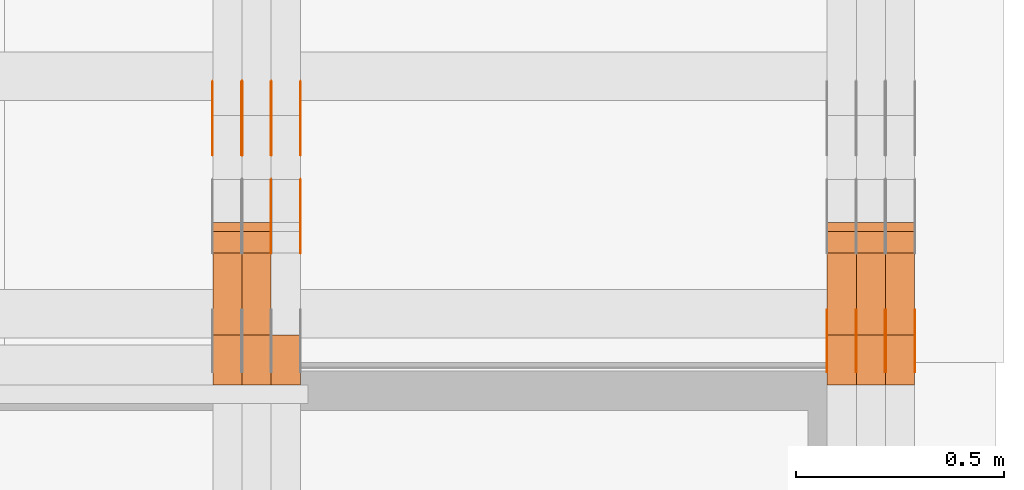
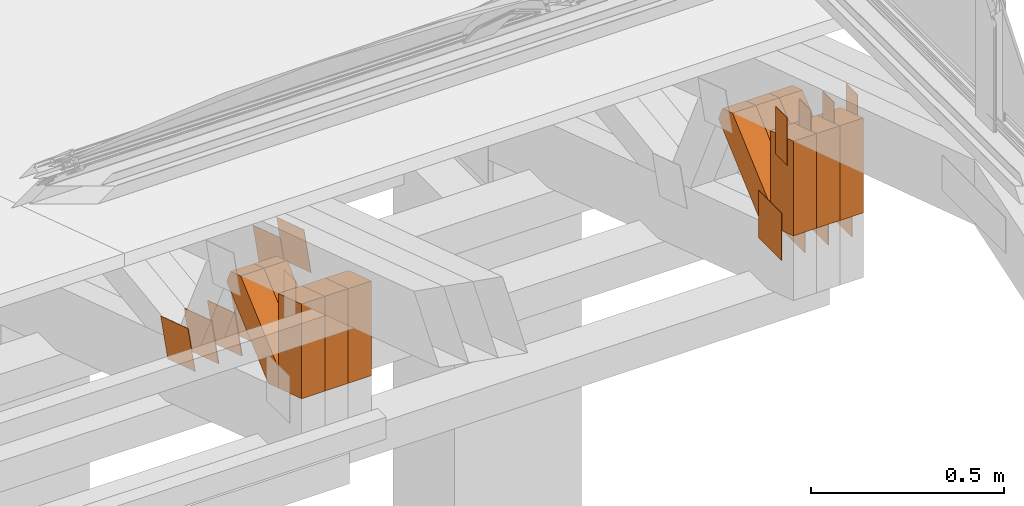
# One storey, part 325 of 385: 31 proxies.
"""IFC2X3 building model written with IfcOpenShell, lengths in millimetres."""

from ifc_helpers import new_model, entity, si_unit, converted_unit, derived_unit, direction, frame, origin, origin_2d_with_axis, place, context, subcontext, project, spatial, polyline, rectangle, outline, extrude, source, transform, mapped, material, type_object, type_shapes, element, save


model = new_model("IFC2X3")

# Units and contexts
model_context = context("Model", 3, precision=0.01, world=origin(), true_north=direction((6.12303176911189e-17, 1.0)))
body_context = subcontext(model_context, "Body", "Model", "MODEL_VIEW")
ifc_project = project(units=[si_unit("LENGTHUNIT", "METRE", prefix="MILLI"), si_unit("AREAUNIT", "SQUARE_METRE"), si_unit("VOLUMEUNIT", "CUBIC_METRE"), converted_unit("PLANEANGLEUNIT", "DEGREE", entity("IfcRatioMeasure", 0.0174532925199433), si_unit("PLANEANGLEUNIT", "RADIAN"), dimensions=[0, 0, 0, 0, 0, 0, 0]), si_unit("MASSUNIT", "GRAM", prefix="KILO"), derived_unit("MASSDENSITYUNIT", [(si_unit("MASSUNIT", "GRAM", prefix="KILO"), 1), (si_unit("LENGTHUNIT", "METRE"), -3)]), si_unit("TIMEUNIT", "SECOND"), si_unit("FREQUENCYUNIT", "HERTZ"), si_unit("THERMODYNAMICTEMPERATUREUNIT", "DEGREE_CELSIUS"), derived_unit("THERMALTRANSMITTANCEUNIT", [(si_unit("MASSUNIT", "GRAM", prefix="KILO"), 1), (si_unit("THERMODYNAMICTEMPERATUREUNIT", "KELVIN"), -1), (si_unit("TIMEUNIT", "SECOND"), -3)]), derived_unit("VOLUMETRICFLOWRATEUNIT", [(si_unit("LENGTHUNIT", "METRE"), 3), (si_unit("TIMEUNIT", "SECOND"), -1)]), si_unit("ELECTRICCURRENTUNIT", "AMPERE"), si_unit("ELECTRICVOLTAGEUNIT", "VOLT"), si_unit("POWERUNIT", "WATT"), si_unit("FORCEUNIT", "NEWTON", prefix="KILO"), si_unit("ILLUMINANCEUNIT", "LUX"), si_unit("LUMINOUSFLUXUNIT", "LUMEN"), si_unit("LUMINOUSINTENSITYUNIT", "CANDELA"), derived_unit("USERDEFINED", [(si_unit("MASSUNIT", "GRAM", prefix="KILO"), -1), (si_unit("LENGTHUNIT", "METRE"), -2), (si_unit("TIMEUNIT", "SECOND"), 3), (si_unit("LUMINOUSFLUXUNIT", "LUMEN"), 1)]), derived_unit("LINEARVELOCITYUNIT", [(si_unit("LENGTHUNIT", "METRE"), 1), (si_unit("TIMEUNIT", "SECOND"), -1)]), si_unit("PRESSUREUNIT", "PASCAL"), derived_unit("USERDEFINED", [(si_unit("LENGTHUNIT", "METRE"), -2), (si_unit("MASSUNIT", "GRAM", prefix="KILO"), 1), (si_unit("TIMEUNIT", "SECOND"), -2)])], contexts=[model_context])

# Site, building, storey
site_placement = place(None, origin())
site = spatial("IfcSite", under=ifc_project, at=site_placement, CompositionType="ELEMENT")
building_placement = place(site_placement, origin())
building = spatial("IfcBuilding", under=site, at=building_placement, CompositionType="ELEMENT")
storey_placement = place(building_placement, origin())
storey = spatial("IfcBuildingStorey", under=building, at=storey_placement, Name="Default", CompositionType="ELEMENT", Elevation=0.0)

# Proxies
ifc_material_1 = material(Name="IfcSurfaceStyle #618562")
building_element_proxy_type_1 = type_object("IfcBuildingElementProxyType", PredefinedType="NOTDEFINED", material=ifc_material_1)
shared_shape_1 = source(origin(), body_context, "Body", "SweptSolid", [
    extrude(rectangle(XDim=150.0, YDim=120.0, at=origin_2d_with_axis()), frame((75.0, 60.0, 0.0), z_axis=(0.0, 0.0, 1.0), x_axis=(-1.0, 0.0, 0.0)), (0.0, 0.0, 1.0), 1.3),
])
type_shapes(building_element_proxy_type_1, [shared_shape_1])
proxy_1_placement = place(building_placement, frame((49861.3, 15840.0, 3652.70166015625), z_axis=(-1.0, 0.0, 0.0), x_axis=(0.0, 0.0, -1.0)))
element("IfcBuildingElementProxy", 1, at=proxy_1_placement, inside=storey, type_object=building_element_proxy_type_1, material=ifc_material_1, context=body_context, shape_type="MappedRepresentation", body=[
    mapped(shared_shape_1, transform((0.0, 0.0, 0.0), scale=1.0)),
])
ifc_material_2 = material(Name="IfcSurfaceStyle #618505")
building_element_proxy_type_2 = type_object("IfcBuildingElementProxyType", PredefinedType="NOTDEFINED", material=ifc_material_2)
shared_shape_2 = source(origin(), body_context, "Body", "SweptSolid", [
    extrude(rectangle(XDim=150.0, YDim=120.0, at=origin_2d_with_axis()), frame((75.0, 60.0, 0.0), z_axis=(0.0, 0.0, 1.0), x_axis=(-1.0, 0.0, 0.0)), (0.0, 0.0, 1.0), 1.3),
])
type_shapes(building_element_proxy_type_2, [shared_shape_2])
proxy_2_placement = place(building_placement, frame((49790.0, 15840.0, 3652.70166015625), z_axis=(-1.0, 0.0, 0.0), x_axis=(0.0, 0.0, -1.0)))
element("IfcBuildingElementProxy", 2, at=proxy_2_placement, inside=storey, type_object=building_element_proxy_type_2, material=ifc_material_2, context=body_context, shape_type="MappedRepresentation", body=[
    mapped(shared_shape_2, transform((0.0, 0.0, 0.0), scale=1.0)),
])
ifc_material_3 = material(Name="IfcSurfaceStyle #618448")
building_element_proxy_type_3 = type_object("IfcBuildingElementProxyType", PredefinedType="NOTDEFINED", material=ifc_material_3)
shared_shape_3 = source(origin(), body_context, "Body", "SweptSolid", [
    extrude(rectangle(XDim=150.0, YDim=120.0, at=origin_2d_with_axis()), frame((75.0, 60.0, 0.0), z_axis=(0.0, 0.0, 1.0), x_axis=(-1.0, 0.0, 0.0)), (0.0, 0.0, 1.0), 1.3),
])
type_shapes(building_element_proxy_type_3, [shared_shape_3])
proxy_3_placement = place(building_placement, frame((49791.3, 15840.0, 3652.70166015625), z_axis=(-1.0, 0.0, 0.0), x_axis=(0.0, 0.0, -1.0)))
element("IfcBuildingElementProxy", 3, at=proxy_3_placement, inside=storey, type_object=building_element_proxy_type_3, material=ifc_material_3, context=body_context, shape_type="MappedRepresentation", body=[
    mapped(shared_shape_3, transform((0.0, 0.0, 0.0), scale=1.0)),
])
ifc_material_4 = material(Name="IfcSurfaceStyle #618391")
building_element_proxy_type_4 = type_object("IfcBuildingElementProxyType", PredefinedType="NOTDEFINED", material=ifc_material_4)
shared_shape_4 = source(origin(), body_context, "Body", "SweptSolid", [
    extrude(rectangle(XDim=150.0, YDim=120.0, at=origin_2d_with_axis()), frame((75.0, 60.0, 0.0), z_axis=(0.0, 0.0, 1.0), x_axis=(-1.0, 0.0, 0.0)), (0.0, 0.0, 1.0), 1.29999999999999),
])
type_shapes(building_element_proxy_type_4, [shared_shape_4])
proxy_4_placement = place(building_placement, frame((49720.0, 15840.0, 3652.70166015625), z_axis=(-1.0, 0.0, 0.0), x_axis=(0.0, 0.0, -1.0)))
element("IfcBuildingElementProxy", 4, at=proxy_4_placement, inside=storey, type_object=building_element_proxy_type_4, material=ifc_material_4, context=body_context, shape_type="MappedRepresentation", body=[
    mapped(shared_shape_4, transform((0.0, 0.0, 0.0), scale=1.0)),
])
ifc_material_5 = material(Name="IfcSurfaceStyle #618334")
building_element_proxy_type_5 = type_object("IfcBuildingElementProxyType", PredefinedType="NOTDEFINED", material=ifc_material_5)
shared_shape_5 = source(origin(), body_context, "Body", "SweptSolid", [
    extrude(rectangle(XDim=150.0, YDim=120.0, at=origin_2d_with_axis()), frame((75.0, 60.0, 0.0), z_axis=(0.0, 0.0, 1.0), x_axis=(-1.0, 0.0, 0.0)), (0.0, 0.0, 1.0), 1.29999999999999),
])
type_shapes(building_element_proxy_type_5, [shared_shape_5])
proxy_5_placement = place(building_placement, frame((49721.3, 15840.0, 3652.70166015625), z_axis=(-1.0, 0.0, 0.0), x_axis=(0.0, 0.0, -1.0)))
element("IfcBuildingElementProxy", 5, at=proxy_5_placement, inside=storey, type_object=building_element_proxy_type_5, material=ifc_material_5, context=body_context, shape_type="MappedRepresentation", body=[
    mapped(shared_shape_5, transform((0.0, 0.0, 0.0), scale=1.0)),
])
ifc_material_6 = material(Name="IfcSurfaceStyle #618277")
building_element_proxy_type_6 = type_object("IfcBuildingElementProxyType", PredefinedType="NOTDEFINED", material=ifc_material_6)
shared_shape_6 = source(origin(), body_context, "Body", "SweptSolid", [
    extrude(rectangle(XDim=150.0, YDim=120.0, at=origin_2d_with_axis()), frame((75.0, 60.0, 0.0), z_axis=(0.0, 0.0, 1.0), x_axis=(-1.0, 0.0, 0.0)), (0.0, 0.0, 1.0), 1.29999999999999),
])
type_shapes(building_element_proxy_type_6, [shared_shape_6])
proxy_6_placement = place(building_placement, frame((49650.0, 15840.0, 3652.70166015625), z_axis=(-1.0, 0.0, 0.0), x_axis=(0.0, 0.0, -1.0)))
element("IfcBuildingElementProxy", 6, at=proxy_6_placement, inside=storey, type_object=building_element_proxy_type_6, material=ifc_material_6, context=body_context, shape_type="MappedRepresentation", body=[
    mapped(shared_shape_6, transform((0.0, 0.0, 0.0), scale=1.0)),
])
ifc_material_7 = material(Name="IfcSurfaceStyle #613090")
building_element_proxy_type_7 = type_object("IfcBuildingElementProxyType", PredefinedType="NOTDEFINED", material=ifc_material_7)
shared_shape_7 = source(origin(), body_context, "Body", "SweptSolid", [
    extrude(rectangle(XDim=150.0, YDim=60.0, at=origin_2d_with_axis()), frame((75.0000705696311, 30.0, 0.0), z_axis=(0.0, 0.0, 1.0), x_axis=(-1.0, 0.0, 0.0)), (0.0, 0.0, 1.0), 1.3),
])
type_shapes(building_element_proxy_type_7, [shared_shape_7])
proxy_7_placement = place(building_placement, frame((49861.3, 15750.0, 3972.59919166338), z_axis=(-1.0, 0.0, 0.0), x_axis=(0.0, 0.0, -1.0)))
element("IfcBuildingElementProxy", 7, at=proxy_7_placement, inside=storey, type_object=building_element_proxy_type_7, material=ifc_material_7, context=body_context, shape_type="MappedRepresentation", body=[
    mapped(shared_shape_7, transform((0.0, 0.0, 0.0), scale=1.0)),
])
ifc_material_8 = material(Name="IfcSurfaceStyle #613033")
building_element_proxy_type_8 = type_object("IfcBuildingElementProxyType", PredefinedType="NOTDEFINED", material=ifc_material_8)
shared_shape_8 = source(origin(), body_context, "Body", "SweptSolid", [
    extrude(rectangle(XDim=150.0, YDim=60.0, at=origin_2d_with_axis()), frame((75.0000705696311, 30.0, 0.0), z_axis=(0.0, 0.0, 1.0), x_axis=(-1.0, 0.0, 0.0)), (0.0, 0.0, 1.0), 1.3),
])
type_shapes(building_element_proxy_type_8, [shared_shape_8])
proxy_8_placement = place(building_placement, frame((49790.0, 15750.0, 3972.59919166338), z_axis=(-1.0, 0.0, 0.0), x_axis=(0.0, 0.0, -1.0)))
element("IfcBuildingElementProxy", 8, at=proxy_8_placement, inside=storey, type_object=building_element_proxy_type_8, material=ifc_material_8, context=body_context, shape_type="MappedRepresentation", body=[
    mapped(shared_shape_8, transform((0.0, 0.0, 0.0), scale=1.0)),
])
ifc_material_9 = material(Name="IfcSurfaceStyle #612976")
building_element_proxy_type_9 = type_object("IfcBuildingElementProxyType", PredefinedType="NOTDEFINED", material=ifc_material_9)
shared_shape_9 = source(origin(), body_context, "Body", "SweptSolid", [
    extrude(rectangle(XDim=150.0, YDim=60.0, at=origin_2d_with_axis()), frame((75.0000705696311, 30.0, 0.0), z_axis=(0.0, 0.0, 1.0), x_axis=(-1.0, 0.0, 0.0)), (0.0, 0.0, 1.0), 1.3),
])
type_shapes(building_element_proxy_type_9, [shared_shape_9])
proxy_9_placement = place(building_placement, frame((49791.3, 15750.0, 3972.59919166338), z_axis=(-1.0, 0.0, 0.0), x_axis=(0.0, 0.0, -1.0)))
element("IfcBuildingElementProxy", 9, at=proxy_9_placement, inside=storey, type_object=building_element_proxy_type_9, material=ifc_material_9, context=body_context, shape_type="MappedRepresentation", body=[
    mapped(shared_shape_9, transform((0.0, 0.0, 0.0), scale=1.0)),
])
ifc_material_10 = material(Name="IfcSurfaceStyle #612919")
building_element_proxy_type_10 = type_object("IfcBuildingElementProxyType", PredefinedType="NOTDEFINED", material=ifc_material_10)
shared_shape_10 = source(origin(), body_context, "Body", "SweptSolid", [
    extrude(rectangle(XDim=150.0, YDim=60.0, at=origin_2d_with_axis()), frame((75.0000705696311, 30.0, 0.0), z_axis=(0.0, 0.0, 1.0), x_axis=(-1.0, 0.0, 0.0)), (0.0, 0.0, 1.0), 1.29999999999999),
])
type_shapes(building_element_proxy_type_10, [shared_shape_10])
proxy_10_placement = place(building_placement, frame((49720.0, 15750.0, 3972.59919166338), z_axis=(-1.0, 0.0, 0.0), x_axis=(0.0, 0.0, -1.0)))
element("IfcBuildingElementProxy", 10, at=proxy_10_placement, inside=storey, type_object=building_element_proxy_type_10, material=ifc_material_10, context=body_context, shape_type="MappedRepresentation", body=[
    mapped(shared_shape_10, transform((0.0, 0.0, 0.0), scale=1.0)),
])
ifc_material_11 = material(Name="IfcSurfaceStyle #612862")
building_element_proxy_type_11 = type_object("IfcBuildingElementProxyType", PredefinedType="NOTDEFINED", material=ifc_material_11)
shared_shape_11 = source(origin(), body_context, "Body", "SweptSolid", [
    extrude(rectangle(XDim=150.0, YDim=60.0, at=origin_2d_with_axis()), frame((75.0000705696311, 30.0, 0.0), z_axis=(0.0, 0.0, 1.0), x_axis=(-1.0, 0.0, 0.0)), (0.0, 0.0, 1.0), 1.29999999999999),
])
type_shapes(building_element_proxy_type_11, [shared_shape_11])
proxy_11_placement = place(building_placement, frame((49721.3, 15750.0, 3972.59919166338), z_axis=(-1.0, 0.0, 0.0), x_axis=(0.0, 0.0, -1.0)))
element("IfcBuildingElementProxy", 11, at=proxy_11_placement, inside=storey, type_object=building_element_proxy_type_11, material=ifc_material_11, context=body_context, shape_type="MappedRepresentation", body=[
    mapped(shared_shape_11, transform((0.0, 0.0, 0.0), scale=1.0)),
])
ifc_material_12 = material(Name="IfcSurfaceStyle #612805")
building_element_proxy_type_12 = type_object("IfcBuildingElementProxyType", PredefinedType="NOTDEFINED", material=ifc_material_12)
shared_shape_12 = source(origin(), body_context, "Body", "SweptSolid", [
    extrude(rectangle(XDim=150.0, YDim=60.0, at=origin_2d_with_axis()), frame((75.0000705696311, 30.0, 0.0), z_axis=(0.0, 0.0, 1.0), x_axis=(-1.0, 0.0, 0.0)), (0.0, 0.0, 1.0), 1.29999999999999),
])
type_shapes(building_element_proxy_type_12, [shared_shape_12])
proxy_12_placement = place(building_placement, frame((49650.0, 15750.0, 3972.59919166338), z_axis=(-1.0, 0.0, 0.0), x_axis=(0.0, 0.0, -1.0)))
element("IfcBuildingElementProxy", 12, at=proxy_12_placement, inside=storey, type_object=building_element_proxy_type_12, material=ifc_material_12, context=body_context, shape_type="MappedRepresentation", body=[
    mapped(shared_shape_12, transform((0.0, 0.0, 0.0), scale=1.0)),
])
ifc_material_13 = material(Name="IfcSurfaceStyle #603721")
building_element_proxy_type_13 = type_object("IfcBuildingElementProxyType", Name="T2-W50 603719", PredefinedType="NOTDEFINED", material=ifc_material_13)
shared_shape_13 = source(origin(), body_context, "Body", "SweptSolid", [
    extrude(outline(polyline([(-128.56619634284, -47.4999385885712), (133.151257249084, -47.4999385885712), (161.172800006526, -0.000129729183733609), (147.291467726413, 47.500068317755), (-142.513973767368, 47.500068317755), (-170.535354871815, -0.000129729183754689), (-128.56619634284, -47.4999385885712)])), frame((161.17310141218, 47.5001898716564, 0.0), z_axis=(0.0, 0.0, 1.0), x_axis=(-1.0, 0.0, 0.0)), (0.0, 0.0, 1.0), 70.0),
])
type_shapes(building_element_proxy_type_13, [shared_shape_13])
proxy_13_placement = place(building_placement, frame((49860.0, 16060.0297689714, 3761.73994820667), z_axis=(-1.0, 0.0, 0.0), x_axis=(0.0, -0.749388407538668, -0.662130662820156)))
element("IfcBuildingElementProxy", 13, at=proxy_13_placement, inside=storey, type_object=building_element_proxy_type_13, material=ifc_material_13, Name="T2-W50", context=body_context, shape_type="MappedRepresentation", body=[
    mapped(shared_shape_13, transform((0.0, 0.0, 0.0), scale=1.0)),
])
ifc_material_14 = material(Name="IfcSurfaceStyle #603646")
building_element_proxy_type_14 = type_object("IfcBuildingElementProxyType", Name="T2-W50 603644", PredefinedType="NOTDEFINED", material=ifc_material_14)
shared_shape_14 = source(origin(), body_context, "Body", "SweptSolid", [
    extrude(outline(polyline([(-128.56619634284, -47.4999385885712), (133.151257249084, -47.4999385885712), (161.172800006526, -0.000129729183733609), (147.291467726413, 47.500068317755), (-142.513973767368, 47.500068317755), (-170.535354871815, -0.000129729183754689), (-128.56619634284, -47.4999385885712)])), frame((161.17310141218, 47.5001898716564, 0.0), z_axis=(0.0, 0.0, 1.0), x_axis=(-1.0, 0.0, 0.0)), (0.0, 0.0, 1.0), 70.0),
])
type_shapes(building_element_proxy_type_14, [shared_shape_14])
proxy_14_placement = place(building_placement, frame((49790.0, 16060.0297689714, 3761.73994820667), z_axis=(-1.0, 0.0, 0.0), x_axis=(0.0, -0.749388407538668, -0.662130662820156)))
element("IfcBuildingElementProxy", 14, at=proxy_14_placement, inside=storey, type_object=building_element_proxy_type_14, material=ifc_material_14, Name="T2-W50", context=body_context, shape_type="MappedRepresentation", body=[
    mapped(shared_shape_14, transform((0.0, 0.0, 0.0), scale=1.0)),
])
ifc_material_15 = material(Name="IfcSurfaceStyle #603571")
building_element_proxy_type_15 = type_object("IfcBuildingElementProxyType", Name="T2-W50 603569", PredefinedType="NOTDEFINED", material=ifc_material_15)
shared_shape_15 = source(origin(), body_context, "Body", "SweptSolid", [
    extrude(outline(polyline([(-128.56619634284, -47.4999385885712), (133.151257249084, -47.4999385885712), (161.172800006526, -0.000129729183733609), (147.291467726413, 47.500068317755), (-142.513973767368, 47.500068317755), (-170.535354871815, -0.000129729183754689), (-128.56619634284, -47.4999385885712)])), frame((161.17310141218, 47.5001898716564, 0.0), z_axis=(0.0, 0.0, 1.0), x_axis=(-1.0, 0.0, 0.0)), (0.0, 0.0, 1.0), 70.0),
])
type_shapes(building_element_proxy_type_15, [shared_shape_15])
proxy_15_placement = place(building_placement, frame((49720.0, 16060.0297689714, 3761.73994820667), z_axis=(-1.0, 0.0, 0.0), x_axis=(0.0, -0.749388407538668, -0.662130662820156)))
element("IfcBuildingElementProxy", 15, at=proxy_15_placement, inside=storey, type_object=building_element_proxy_type_15, material=ifc_material_15, Name="T2-W50", context=body_context, shape_type="MappedRepresentation", body=[
    mapped(shared_shape_15, transform((0.0, 0.0, 0.0), scale=1.0)),
])
ifc_material_16 = material(Name="IfcSurfaceStyle #603325")
building_element_proxy_type_16 = type_object("IfcBuildingElementProxyType", Name="T2-W2 603323", PredefinedType="NOTDEFINED", material=ifc_material_16)
shared_shape_16 = source(origin(), body_context, "Body", "SweptSolid", [
    extrude(outline(polyline([(-130.705993652344, -60.0), (169.696350097656, -60.0), (130.706115722656, 60.0), (-169.696472167969, 60.0), (-130.705993652344, -60.0)])), frame((169.696429629256, 60.0, 0.0), z_axis=(0.0, 0.0, 1.0), x_axis=(-1.0, 0.0, 0.0)), (0.0, 0.0, 1.0), 70.0),
])
type_shapes(building_element_proxy_type_16, [shared_shape_16])
proxy_16_placement = place(building_placement, frame((49860.0, 15660.0, 3577.70158062465), z_axis=(-1.0, 0.0, 0.0), x_axis=(0.0, 0.0, 1.0)))
element("IfcBuildingElementProxy", 16, at=proxy_16_placement, inside=storey, type_object=building_element_proxy_type_16, material=ifc_material_16, Name="T2-W2", context=body_context, shape_type="MappedRepresentation", body=[
    mapped(shared_shape_16, transform((0.0, 0.0, 0.0), scale=1.0)),
])
ifc_material_17 = material(Name="IfcSurfaceStyle #603268")
building_element_proxy_type_17 = type_object("IfcBuildingElementProxyType", Name="T2-W2 603266", PredefinedType="NOTDEFINED", material=ifc_material_17)
shared_shape_17 = source(origin(), body_context, "Body", "SweptSolid", [
    extrude(outline(polyline([(-130.705993652344, -60.0), (169.696350097656, -60.0), (130.706115722656, 60.0), (-169.696472167969, 60.0), (-130.705993652344, -60.0)])), frame((169.696429629256, 60.0, 0.0), z_axis=(0.0, 0.0, 1.0), x_axis=(-1.0, 0.0, 0.0)), (0.0, 0.0, 1.0), 70.0),
])
type_shapes(building_element_proxy_type_17, [shared_shape_17])
proxy_17_placement = place(building_placement, frame((49790.0, 15660.0, 3577.70158062465), z_axis=(-1.0, 0.0, 0.0), x_axis=(0.0, 0.0, 1.0)))
element("IfcBuildingElementProxy", 17, at=proxy_17_placement, inside=storey, type_object=building_element_proxy_type_17, material=ifc_material_17, Name="T2-W2", context=body_context, shape_type="MappedRepresentation", body=[
    mapped(shared_shape_17, transform((0.0, 0.0, 0.0), scale=1.0)),
])
ifc_material_18 = material(Name="IfcSurfaceStyle #603211")
building_element_proxy_type_18 = type_object("IfcBuildingElementProxyType", Name="T2-W2 603209", PredefinedType="NOTDEFINED", material=ifc_material_18)
shared_shape_18 = source(origin(), body_context, "Body", "SweptSolid", [
    extrude(outline(polyline([(-130.705993652344, -60.0), (169.696350097656, -60.0), (130.706115722656, 60.0), (-169.696472167969, 60.0), (-130.705993652344, -60.0)])), frame((169.696429629256, 60.0, 0.0), z_axis=(0.0, 0.0, 1.0), x_axis=(-1.0, 0.0, 0.0)), (0.0, 0.0, 1.0), 70.0),
])
type_shapes(building_element_proxy_type_18, [shared_shape_18])
proxy_18_placement = place(building_placement, frame((49720.0, 15660.0, 3577.70158062465), z_axis=(-1.0, 0.0, 0.0), x_axis=(0.0, 0.0, 1.0)))
element("IfcBuildingElementProxy", 18, at=proxy_18_placement, inside=storey, type_object=building_element_proxy_type_18, material=ifc_material_18, Name="T2-W2", context=body_context, shape_type="MappedRepresentation", body=[
    mapped(shared_shape_18, transform((0.0, 0.0, 0.0), scale=1.0)),
])
ifc_material_19 = material(Name="IfcSurfaceStyle #583788")
building_element_proxy_type_19 = type_object("IfcBuildingElementProxyType", PredefinedType="NOTDEFINED", material=ifc_material_19)
shared_shape_19 = source(origin(), body_context, "Body", "SweptSolid", [
    extrude(outline(polyline([(-74.9998605591118, -59.9999264677601), (74.9998754286171, -59.9999264677601), (74.9998605591118, 59.9999264677602), (-74.9998754286171, 59.9999264677602), (-74.9998605591118, -59.9999264677601)])), frame((74.9998754286171, 60.0000503992849, 0.0), z_axis=(0.0, 0.0, 1.0), x_axis=(-1.0, 0.0, 0.0)), (0.0, 0.0, 1.0), 1.3),
])
type_shapes(building_element_proxy_type_19, [shared_shape_19])
proxy_19_placement = place(building_placement, frame((48386.3, 16352.8320303235, 3323.23212676408), z_axis=(-1.0, 0.0, 0.0), x_axis=(0.0, -0.951056516295124, 0.309016994375039)))
element("IfcBuildingElementProxy", 19, at=proxy_19_placement, inside=storey, type_object=building_element_proxy_type_19, material=ifc_material_19, context=body_context, shape_type="MappedRepresentation", body=[
    mapped(shared_shape_19, transform((0.0, 0.0, 0.0), scale=1.0)),
])
ifc_material_20 = material(Name="IfcSurfaceStyle #583731")
building_element_proxy_type_20 = type_object("IfcBuildingElementProxyType", PredefinedType="NOTDEFINED", material=ifc_material_20)
shared_shape_20 = source(origin(), body_context, "Body", "SweptSolid", [
    extrude(outline(polyline([(-74.9998605591118, -59.9999264677601), (74.9998754286171, -59.9999264677601), (74.9998605591118, 59.9999264677602), (-74.9998754286171, 59.9999264677602), (-74.9998605591118, -59.9999264677601)])), frame((74.9998754286171, 60.0000503992849, 0.0), z_axis=(0.0, 0.0, 1.0), x_axis=(-1.0, 0.0, 0.0)), (0.0, 0.0, 1.0), 1.3),
])
type_shapes(building_element_proxy_type_20, [shared_shape_20])
proxy_20_placement = place(building_placement, frame((48315.0, 16352.8320303235, 3323.23212676408), z_axis=(-1.0, 0.0, 0.0), x_axis=(0.0, -0.951056516295124, 0.309016994375039)))
element("IfcBuildingElementProxy", 20, at=proxy_20_placement, inside=storey, type_object=building_element_proxy_type_20, material=ifc_material_20, context=body_context, shape_type="MappedRepresentation", body=[
    mapped(shared_shape_20, transform((0.0, 0.0, 0.0), scale=1.0)),
])
ifc_material_21 = material(Name="IfcSurfaceStyle #583674")
building_element_proxy_type_21 = type_object("IfcBuildingElementProxyType", PredefinedType="NOTDEFINED", material=ifc_material_21)
shared_shape_21 = source(origin(), body_context, "Body", "SweptSolid", [
    extrude(outline(polyline([(-74.9998605591118, -59.9999264677601), (74.9998754286171, -59.9999264677601), (74.9998605591118, 59.9999264677602), (-74.9998754286171, 59.9999264677602), (-74.9998605591118, -59.9999264677601)])), frame((74.9998754286171, 60.0000503992849, 0.0), z_axis=(0.0, 0.0, 1.0), x_axis=(-1.0, 0.0, 0.0)), (0.0, 0.0, 1.0), 1.3),
])
type_shapes(building_element_proxy_type_21, [shared_shape_21])
proxy_21_placement = place(building_placement, frame((48316.3, 16352.8320303235, 3323.23212676408), z_axis=(-1.0, 0.0, 0.0), x_axis=(0.0, -0.951056516295124, 0.309016994375039)))
element("IfcBuildingElementProxy", 21, at=proxy_21_placement, inside=storey, type_object=building_element_proxy_type_21, material=ifc_material_21, context=body_context, shape_type="MappedRepresentation", body=[
    mapped(shared_shape_21, transform((0.0, 0.0, 0.0), scale=1.0)),
])
ifc_material_22 = material(Name="IfcSurfaceStyle #583617")
building_element_proxy_type_22 = type_object("IfcBuildingElementProxyType", PredefinedType="NOTDEFINED", material=ifc_material_22)
shared_shape_22 = source(origin(), body_context, "Body", "SweptSolid", [
    extrude(outline(polyline([(-74.9998605591118, -59.9999264677601), (74.9998754286171, -59.9999264677601), (74.9998605591118, 59.9999264677602), (-74.9998754286171, 59.9999264677602), (-74.9998605591118, -59.9999264677601)])), frame((74.9998754286171, 60.0000503992849, 0.0), z_axis=(0.0, 0.0, 1.0), x_axis=(-1.0, 0.0, 0.0)), (0.0, 0.0, 1.0), 1.29999999999999),
])
type_shapes(building_element_proxy_type_22, [shared_shape_22])
proxy_22_placement = place(building_placement, frame((48245.0, 16352.8320303235, 3323.23212676408), z_axis=(-1.0, 0.0, 0.0), x_axis=(0.0, -0.951056516295124, 0.309016994375039)))
element("IfcBuildingElementProxy", 22, at=proxy_22_placement, inside=storey, type_object=building_element_proxy_type_22, material=ifc_material_22, context=body_context, shape_type="MappedRepresentation", body=[
    mapped(shared_shape_22, transform((0.0, 0.0, 0.0), scale=1.0)),
])
ifc_material_23 = material(Name="IfcSurfaceStyle #583560")
building_element_proxy_type_23 = type_object("IfcBuildingElementProxyType", PredefinedType="NOTDEFINED", material=ifc_material_23)
shared_shape_23 = source(origin(), body_context, "Body", "SweptSolid", [
    extrude(outline(polyline([(-74.9998605591118, -59.9999264677601), (74.9998754286171, -59.9999264677601), (74.9998605591118, 59.9999264677602), (-74.9998754286171, 59.9999264677602), (-74.9998605591118, -59.9999264677601)])), frame((74.9998754286171, 60.0000503992849, 0.0), z_axis=(0.0, 0.0, 1.0), x_axis=(-1.0, 0.0, 0.0)), (0.0, 0.0, 1.0), 1.29999999999999),
])
type_shapes(building_element_proxy_type_23, [shared_shape_23])
proxy_23_placement = place(building_placement, frame((48246.3, 16352.8320303235, 3323.23212676408), z_axis=(-1.0, 0.0, 0.0), x_axis=(0.0, -0.951056516295124, 0.309016994375039)))
element("IfcBuildingElementProxy", 23, at=proxy_23_placement, inside=storey, type_object=building_element_proxy_type_23, material=ifc_material_23, context=body_context, shape_type="MappedRepresentation", body=[
    mapped(shared_shape_23, transform((0.0, 0.0, 0.0), scale=1.0)),
])
ifc_material_24 = material(Name="IfcSurfaceStyle #583503")
building_element_proxy_type_24 = type_object("IfcBuildingElementProxyType", PredefinedType="NOTDEFINED", material=ifc_material_24)
shared_shape_24 = source(origin(), body_context, "Body", "SweptSolid", [
    extrude(outline(polyline([(-74.9998605591118, -59.9999264677601), (74.9998754286171, -59.9999264677601), (74.9998605591118, 59.9999264677602), (-74.9998754286171, 59.9999264677602), (-74.9998605591118, -59.9999264677601)])), frame((74.9998754286171, 60.0000503992849, 0.0), z_axis=(0.0, 0.0, 1.0), x_axis=(-1.0, 0.0, 0.0)), (0.0, 0.0, 1.0), 1.29999999999999),
])
type_shapes(building_element_proxy_type_24, [shared_shape_24])
proxy_24_placement = place(building_placement, frame((48175.0, 16352.8320303235, 3323.23212676408), z_axis=(-1.0, 0.0, 0.0), x_axis=(0.0, -0.951056516295124, 0.309016994375039)))
element("IfcBuildingElementProxy", 24, at=proxy_24_placement, inside=storey, type_object=building_element_proxy_type_24, material=ifc_material_24, context=body_context, shape_type="MappedRepresentation", body=[
    mapped(shared_shape_24, transform((0.0, 0.0, 0.0), scale=1.0)),
])
ifc_material_25 = material(Name="IfcSurfaceStyle #579342")
building_element_proxy_type_25 = type_object("IfcBuildingElementProxyType", PredefinedType="NOTDEFINED", material=ifc_material_25)
shared_shape_25 = source(origin(), body_context, "Body", "SweptSolid", [
    extrude(outline(polyline([(-75.0003249421702, -60.0000773549573), (75.0003398116874, -60.0000773549573), (75.0003249421711, 60.0000773549573), (-75.0003398116883, 60.0000773549573), (-75.0003249421702, -60.0000773549573)])), frame((75.0003398116874, 60.0000773549573, 0.0), z_axis=(0.0, 0.0, 1.0), x_axis=(-1.0, 0.0, 0.0)), (0.0, 0.0, 1.0), 1.3),
])
type_shapes(building_element_proxy_type_25, [shared_shape_25])
proxy_25_placement = place(building_placement, frame((48386.3, 16117.0849050545, 3705.49074668796), z_axis=(-1.0, 0.0, 0.0), x_axis=(0.0, -0.951056516295154, 0.309016994374948)))
element("IfcBuildingElementProxy", 25, at=proxy_25_placement, inside=storey, type_object=building_element_proxy_type_25, material=ifc_material_25, context=body_context, shape_type="MappedRepresentation", body=[
    mapped(shared_shape_25, transform((0.0, 0.0, 0.0), scale=1.0)),
])
ifc_material_26 = material(Name="IfcSurfaceStyle #579285")
building_element_proxy_type_26 = type_object("IfcBuildingElementProxyType", PredefinedType="NOTDEFINED", material=ifc_material_26)
shared_shape_26 = source(origin(), body_context, "Body", "SweptSolid", [
    extrude(outline(polyline([(-75.0003249421702, -60.0000773549573), (75.0003398116874, -60.0000773549573), (75.0003249421711, 60.0000773549573), (-75.0003398116883, 60.0000773549573), (-75.0003249421702, -60.0000773549573)])), frame((75.0003398116874, 60.0000773549573, 0.0), z_axis=(0.0, 0.0, 1.0), x_axis=(-1.0, 0.0, 0.0)), (0.0, 0.0, 1.0), 1.3),
])
type_shapes(building_element_proxy_type_26, [shared_shape_26])
proxy_26_placement = place(building_placement, frame((48315.0, 16117.0849050545, 3705.49074668796), z_axis=(-1.0, 0.0, 0.0), x_axis=(0.0, -0.951056516295154, 0.309016994374948)))
element("IfcBuildingElementProxy", 26, at=proxy_26_placement, inside=storey, type_object=building_element_proxy_type_26, material=ifc_material_26, context=body_context, shape_type="MappedRepresentation", body=[
    mapped(shared_shape_26, transform((0.0, 0.0, 0.0), scale=1.0)),
])
ifc_material_27 = material(Name="IfcSurfaceStyle #569214")
building_element_proxy_type_27 = type_object("IfcBuildingElementProxyType", Name="T1-W50 569212", PredefinedType="NOTDEFINED", material=ifc_material_27)
shared_shape_27 = source(origin(), body_context, "Body", "SweptSolid", [
    extrude(outline(polyline([(-128.56619634284, -47.4999385885712), (133.151257249084, -47.4999385885712), (161.172800006526, -0.000129729183733609), (147.291467726413, 47.500068317755), (-142.513973767368, 47.500068317755), (-170.535354871815, -0.000129729183754689), (-128.56619634284, -47.4999385885712)])), frame((161.17310141218, 47.5001898716564, 0.0), z_axis=(0.0, 0.0, 1.0), x_axis=(-1.0, 0.0, 0.0)), (0.0, 0.0, 1.0), 70.0),
])
type_shapes(building_element_proxy_type_27, [shared_shape_27])
proxy_27_placement = place(building_placement, frame((48315.0, 16060.0297689714, 3761.73994820667), z_axis=(-1.0, 0.0, 0.0), x_axis=(0.0, -0.749388407538668, -0.662130662820156)))
element("IfcBuildingElementProxy", 27, at=proxy_27_placement, inside=storey, type_object=building_element_proxy_type_27, material=ifc_material_27, Name="T1-W50", context=body_context, shape_type="MappedRepresentation", body=[
    mapped(shared_shape_27, transform((0.0, 0.0, 0.0), scale=1.0)),
])
ifc_material_28 = material(Name="IfcSurfaceStyle #569139")
building_element_proxy_type_28 = type_object("IfcBuildingElementProxyType", Name="T1-W50 569137", PredefinedType="NOTDEFINED", material=ifc_material_28)
shared_shape_28 = source(origin(), body_context, "Body", "SweptSolid", [
    extrude(outline(polyline([(-128.56619634284, -47.4999385885712), (133.151257249084, -47.4999385885712), (161.172800006526, -0.000129729183733609), (147.291467726413, 47.500068317755), (-142.513973767368, 47.500068317755), (-170.535354871815, -0.000129729183754689), (-128.56619634284, -47.4999385885712)])), frame((161.17310141218, 47.5001898716564, 0.0), z_axis=(0.0, 0.0, 1.0), x_axis=(-1.0, 0.0, 0.0)), (0.0, 0.0, 1.0), 70.0),
])
type_shapes(building_element_proxy_type_28, [shared_shape_28])
proxy_28_placement = place(building_placement, frame((48245.0, 16060.0297689714, 3761.73994820667), z_axis=(-1.0, 0.0, 0.0), x_axis=(0.0, -0.749388407538668, -0.662130662820156)))
element("IfcBuildingElementProxy", 28, at=proxy_28_placement, inside=storey, type_object=building_element_proxy_type_28, material=ifc_material_28, Name="T1-W50", context=body_context, shape_type="MappedRepresentation", body=[
    mapped(shared_shape_28, transform((0.0, 0.0, 0.0), scale=1.0)),
])
ifc_material_29 = material(Name="IfcSurfaceStyle #568893")
building_element_proxy_type_29 = type_object("IfcBuildingElementProxyType", Name="T1-W2 568891", PredefinedType="NOTDEFINED", material=ifc_material_29)
shared_shape_29 = source(origin(), body_context, "Body", "SweptSolid", [
    extrude(outline(polyline([(-130.705993652344, -60.0), (169.696350097656, -60.0), (130.706115722656, 60.0), (-169.696472167969, 60.0), (-130.705993652344, -60.0)])), frame((169.696429629256, 60.0, 0.0), z_axis=(0.0, 0.0, 1.0), x_axis=(-1.0, 0.0, 0.0)), (0.0, 0.0, 1.0), 70.0),
])
type_shapes(building_element_proxy_type_29, [shared_shape_29])
proxy_29_placement = place(building_placement, frame((48385.0, 15660.0, 3577.70158062465), z_axis=(-1.0, 0.0, 0.0), x_axis=(0.0, 0.0, 1.0)))
element("IfcBuildingElementProxy", 29, at=proxy_29_placement, inside=storey, type_object=building_element_proxy_type_29, material=ifc_material_29, Name="T1-W2", context=body_context, shape_type="MappedRepresentation", body=[
    mapped(shared_shape_29, transform((0.0, 0.0, 0.0), scale=1.0)),
])
ifc_material_30 = material(Name="IfcSurfaceStyle #568836")
building_element_proxy_type_30 = type_object("IfcBuildingElementProxyType", Name="T1-W2 568834", PredefinedType="NOTDEFINED", material=ifc_material_30)
shared_shape_30 = source(origin(), body_context, "Body", "SweptSolid", [
    extrude(outline(polyline([(-130.705993652344, -60.0), (169.696350097656, -60.0), (130.706115722656, 60.0), (-169.696472167969, 60.0), (-130.705993652344, -60.0)])), frame((169.696429629256, 60.0, 0.0), z_axis=(0.0, 0.0, 1.0), x_axis=(-1.0, 0.0, 0.0)), (0.0, 0.0, 1.0), 70.0),
])
type_shapes(building_element_proxy_type_30, [shared_shape_30])
proxy_30_placement = place(building_placement, frame((48315.0, 15660.0, 3577.70158062465), z_axis=(-1.0, 0.0, 0.0), x_axis=(0.0, 0.0, 1.0)))
element("IfcBuildingElementProxy", 30, at=proxy_30_placement, inside=storey, type_object=building_element_proxy_type_30, material=ifc_material_30, Name="T1-W2", context=body_context, shape_type="MappedRepresentation", body=[
    mapped(shared_shape_30, transform((0.0, 0.0, 0.0), scale=1.0)),
])
ifc_material_31 = material(Name="IfcSurfaceStyle #568779")
building_element_proxy_type_31 = type_object("IfcBuildingElementProxyType", Name="T1-W2 568777", PredefinedType="NOTDEFINED", material=ifc_material_31)
shared_shape_31 = source(origin(), body_context, "Body", "SweptSolid", [
    extrude(outline(polyline([(-130.705993652344, -60.0), (169.696350097656, -60.0), (130.706115722656, 60.0), (-169.696472167969, 60.0), (-130.705993652344, -60.0)])), frame((169.696429629256, 60.0, 0.0), z_axis=(0.0, 0.0, 1.0), x_axis=(-1.0, 0.0, 0.0)), (0.0, 0.0, 1.0), 70.0),
])
type_shapes(building_element_proxy_type_31, [shared_shape_31])
proxy_31_placement = place(building_placement, frame((48245.0, 15660.0, 3577.70158062465), z_axis=(-1.0, 0.0, 0.0), x_axis=(0.0, 0.0, 1.0)))
element("IfcBuildingElementProxy", 31, at=proxy_31_placement, inside=storey, type_object=building_element_proxy_type_31, material=ifc_material_31, Name="T1-W2", context=body_context, shape_type="MappedRepresentation", body=[
    mapped(shared_shape_31, transform((0.0, 0.0, 0.0), scale=1.0)),
])

save(model, "model.ifc")
